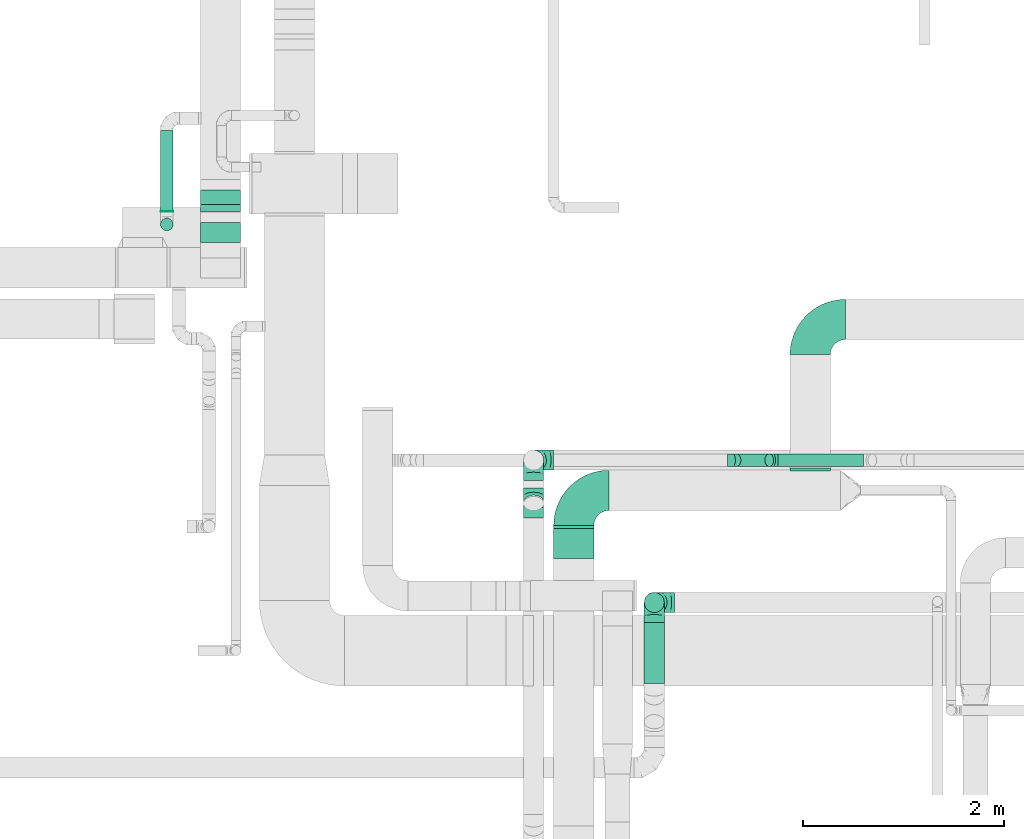
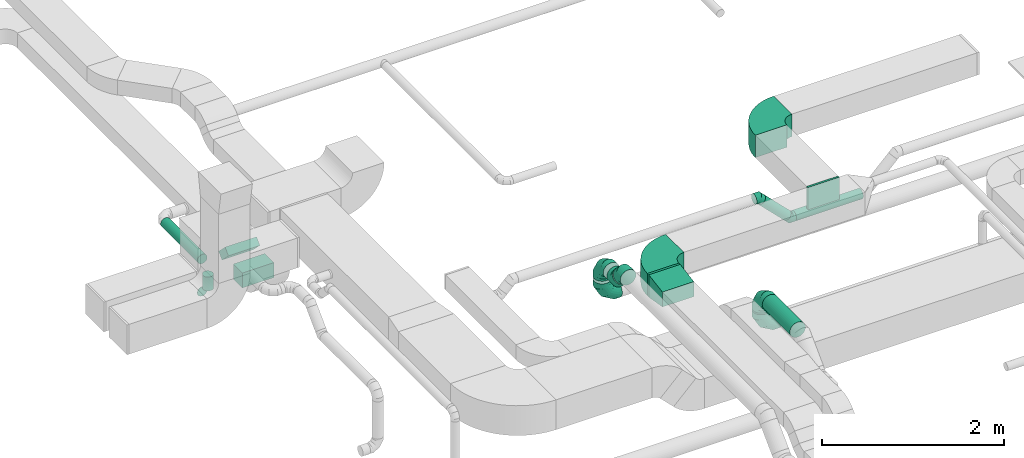
# One storey, part 32 of 60: 12 flow fittings, 10 flow segments.
"""IFC2X3 building model written with IfcOpenShell, lengths in millimetres."""

from ifc_helpers import new_model, entity, si_unit, converted_unit, derived_unit, direction, frame, frame_2d, origin, origin_2d_with_axis, place, context, subcontext, project, spatial, polyline, circle_curve, parameter, trimmed, segment, composite_curve, rectangle, circle, outline, extrude, faceted_brep, source, transform, mapped, material, type_object, type_shapes, element, save


model = new_model("IFC2X3")

# Units and contexts
model_context = context("Model", 3, precision=0.01, world=origin(), true_north=direction((6.12303176911189e-17, 1.0)))
body_context = subcontext(model_context, "Body", "Model", "MODEL_VIEW")
ifc_project = project(units=[si_unit("LENGTHUNIT", "METRE", prefix="MILLI"), si_unit("AREAUNIT", "SQUARE_METRE"), si_unit("VOLUMEUNIT", "CUBIC_METRE"), converted_unit("PLANEANGLEUNIT", "DEGREE", entity("IfcRatioMeasure", 0.0174532925199433), si_unit("PLANEANGLEUNIT", "RADIAN"), dimensions=[0, 0, 0, 0, 0, 0, 0]), si_unit("MASSUNIT", "GRAM", prefix="KILO"), derived_unit("MASSDENSITYUNIT", [(si_unit("MASSUNIT", "GRAM", prefix="KILO"), 1), (si_unit("LENGTHUNIT", "METRE"), -3)]), derived_unit("MOMENTOFINERTIAUNIT", [(si_unit("LENGTHUNIT", "METRE"), 4)]), si_unit("TIMEUNIT", "SECOND"), si_unit("FREQUENCYUNIT", "HERTZ"), si_unit("THERMODYNAMICTEMPERATUREUNIT", "DEGREE_CELSIUS"), derived_unit("THERMALTRANSMITTANCEUNIT", [(si_unit("MASSUNIT", "GRAM", prefix="KILO"), 1), (si_unit("THERMODYNAMICTEMPERATUREUNIT", "KELVIN"), -1), (si_unit("TIMEUNIT", "SECOND"), -3)]), derived_unit("VOLUMETRICFLOWRATEUNIT", [(si_unit("LENGTHUNIT", "METRE"), 3), (si_unit("TIMEUNIT", "SECOND"), -1)]), derived_unit("MASSFLOWRATEUNIT", [(si_unit("MASSUNIT", "GRAM", prefix="KILO"), 1), (si_unit("TIMEUNIT", "SECOND"), -1)]), derived_unit("ROTATIONALFREQUENCYUNIT", [(si_unit("TIMEUNIT", "SECOND"), -1)]), si_unit("ELECTRICCURRENTUNIT", "AMPERE"), si_unit("ELECTRICVOLTAGEUNIT", "VOLT"), si_unit("POWERUNIT", "WATT"), si_unit("FORCEUNIT", "NEWTON", prefix="KILO"), si_unit("ILLUMINANCEUNIT", "LUX"), si_unit("LUMINOUSFLUXUNIT", "LUMEN"), si_unit("LUMINOUSINTENSITYUNIT", "CANDELA"), derived_unit("USERDEFINED", [(si_unit("MASSUNIT", "GRAM", prefix="KILO"), -1), (si_unit("LENGTHUNIT", "METRE"), -2), (si_unit("TIMEUNIT", "SECOND"), 3), (si_unit("LUMINOUSFLUXUNIT", "LUMEN"), 1)]), derived_unit("LINEARVELOCITYUNIT", [(si_unit("LENGTHUNIT", "METRE"), 1), (si_unit("TIMEUNIT", "SECOND"), -1)]), si_unit("PRESSUREUNIT", "PASCAL"), derived_unit("USERDEFINED", [(si_unit("LENGTHUNIT", "METRE"), -2), (si_unit("MASSUNIT", "GRAM", prefix="KILO"), 1), (si_unit("TIMEUNIT", "SECOND"), -2)]), derived_unit("LINEARFORCEUNIT", [(si_unit("MASSUNIT", "GRAM", prefix="KILO"), 1), (si_unit("LENGTHUNIT", "METRE"), 1), (si_unit("TIMEUNIT", "SECOND"), -2), (si_unit("LENGTHUNIT", "METRE"), -1)]), derived_unit("PLANARFORCEUNIT", [(si_unit("MASSUNIT", "GRAM", prefix="KILO"), 1), (si_unit("LENGTHUNIT", "METRE"), 1), (si_unit("TIMEUNIT", "SECOND"), -2), (si_unit("LENGTHUNIT", "METRE"), -2)])], contexts=[model_context])

# Site, building, storey
site_placement = place(None, origin())
site = spatial("IfcSite", under=ifc_project, at=site_placement, CompositionType="ELEMENT")
building_placement = place(site_placement, origin())
building = spatial("IfcBuilding", under=site, at=building_placement, CompositionType="ELEMENT")
storey_placement = place(building_placement, frame((0.0, 0.0, 19800.0)))
storey = spatial("IfcBuildingStorey", under=building, at=storey_placement, CompositionType="ELEMENT", Elevation=19800.0)

# Flow segments
duct_segment_type_1 = type_object("IfcDuctSegmentType", PredefinedType="NOTDEFINED")
flow_segment_1_placement = place(storey_placement, frame((46370.09, 9605.34, 3350.0)))
element("IfcFlowSegment", 1, at=flow_segment_1_placement, inside=storey, type_object=duct_segment_type_1, context=body_context, shape_type="SweptSolid", body=[
    extrude(rectangle(XDim=30.000000000069, YDim=399.999999999996, at=origin_2d_with_axis()), frame((200.0, 15.0, 0.0), z_axis=(0.0, 0.0, 1.0), x_axis=(0.0, -1.0, 0.0)), (0.0, 0.0, 1.0), 300.000000000001),
])
flow_segment_2_placement = place(storey_placement, frame((42853.67, 12449.48, 2980.0)))
element("IfcFlowSegment", 2, at=flow_segment_2_placement, inside=storey, type_object=duct_segment_type_1, context=body_context, shape_type="SweptSolid", body=[
    extrude(rectangle(XDim=201.446609406728, YDim=400.000000000004, at=origin_2d_with_axis()), frame((200.0, 100.72, 0.0), z_axis=(0.0, 0.0, 1.0), x_axis=(0.0, 1.0, 0.0)), (0.0, 0.0, 1.0), 199.999999999998),
])
flow_segment_3_placement = place(storey_placement, frame((42853.67, 12756.99, 3082.51)))
element("IfcFlowSegment", 3, at=flow_segment_3_placement, inside=storey, type_object=duct_segment_type_1, context=body_context, shape_type="SweptSolid", body=[
    extrude(rectangle(XDim=104.020202535497, YDim=200.000000000001, at=origin_2d_with_axis()), frame((0.0, 107.49, 107.49), z_axis=(1.0, 0.0, 0.0), x_axis=(0.0, 0.707106781186443, 0.707106781186652)), (0.0, 0.0, 1.0), 399.999999999996),
])
duct_segment_type_2 = type_object("IfcDuctSegmentType", PredefinedType="NOTDEFINED")
flow_segment_4_placement = place(storey_placement, frame((42457.07, 12756.12, 3235.9)))
element("IfcFlowSegment", 4, at=flow_segment_4_placement, inside=storey, type_object=duct_segment_type_2, context=body_context, shape_type="SweptSolid", body=[
    extrude(circle(Radius=62.5, at=origin_2d_with_axis()), frame((64.1, 0.0, 64.1), z_axis=(0.0, 1.0, 0.0), x_axis=(-1.0, 0.0, 0.0)), (0.0, 0.0, 1.0), 808.750000000011),
])
flow_segment_5_placement = place(storey_placement, frame((42457.07, 12567.03, 2990.0)))
element("IfcFlowSegment", 5, at=flow_segment_5_placement, inside=storey, type_object=duct_segment_type_2, context=body_context, shape_type="SweptSolid", body=[
    extrude(circle(Radius=62.5, at=origin_2d_with_axis()), frame((64.1, 64.1, 0.0), z_axis=(0.0, 0.0, 1.0), x_axis=(-1.0, 0.0, 0.0)), (0.0, 0.0, 1.0), 185.000000000014),
])
flow_segment_6_placement = place(storey_placement, frame((42457.07, 12756.12, 2800.9)))
element("IfcFlowSegment", 6, at=flow_segment_6_placement, inside=storey, type_object=duct_segment_type_2, context=body_context, shape_type="SweptSolid", body=[
    extrude(circle(Radius=62.5, at=origin_2d_with_axis()), frame((64.1, 0.0, 64.1), z_axis=(0.0, 1.0, 0.0), x_axis=(1.0, 0.0, 0.0)), (0.0, 0.0, 1.0), 4.99999999999886),
])
flow_segment_7_placement = place(storey_placement, frame((47268.96, 8062.84, 3398.4)))
element("IfcFlowSegment", 7, at=flow_segment_7_placement, inside=storey, type_object=duct_segment_type_2, context=body_context, shape_type="SweptSolid", body=[
    extrude(circle(Radius=100.0, at=origin_2d_with_axis()), frame((101.6, 0.0, 101.6), z_axis=(0.0, 1.0, 0.0), x_axis=(-1.0, 0.0, 0.0)), (0.0, 0.0, 1.0), 607.161861453254),
])
flow_segment_8_placement = place(storey_placement, frame((47268.96, 8768.41, 3280.0)))
element("IfcFlowSegment", 8, at=flow_segment_8_placement, inside=storey, type_object=duct_segment_type_2, context=body_context, shape_type="SweptSolid", body=[
    extrude(circle(Radius=100.0, at=origin_2d_with_axis()), frame((101.6, 101.6, 0.0), z_axis=(0.0, 0.0, 1.0), x_axis=(-1.0, 0.0, 0.0)), (0.0, 0.0, 1.0), 20.0000000000171),
])
flow_segment_9_placement = place(storey_placement, frame((48603.52, 10221.52, 3185.9)))
element("IfcFlowSegment", 9, at=flow_segment_9_placement, inside=storey, type_object=duct_segment_type_2, context=body_context, shape_type="SweptSolid", body=[
    extrude(circle(Radius=62.5, at=origin_2d_with_axis()), frame((0.0, 64.1, 64.1), z_axis=(1.0, 0.0, 0.0), x_axis=(0.0, 1.0, 0.0)), (0.0, 0.0, 1.0), 848.406204335727),
])
flow_segment_10_placement = place(storey_placement, frame((48142.57, 10221.52, 3240.82)))
element("IfcFlowSegment", 10, at=flow_segment_10_placement, inside=storey, type_object=duct_segment_type_2, context=body_context, shape_type="SweptSolid", body=[
    extrude(circle(Radius=62.5, at=origin_2d_with_axis()), frame((45.79, 64.1, 372.57), z_axis=(0.707106781186553, 0.0, -0.707106781186542), x_axis=(0.0, 1.0, 0.0)), (0.0, 0.0, 1.0), 462.132034355938),
])

# Flow fittings
ifc_material = material()
duct_fitting_type_1 = type_object("IfcDuctFittingType", PredefinedType="NOTDEFINED", material=ifc_material)
shared_shape_1 = source(origin(), body_context, "Body", "SweptSolid", [
    extrude(rectangle(XDim=400.0, YDim=26.096000000013, at=origin_2d_with_axis()), frame((6.95, 0.0, -150.0), z_axis=(0.0, 0.0, 1.0), x_axis=(0.0, -1.0, 0.0)), (0.0, 0.0, 1.0), 300.0),
])
type_shapes(duct_fitting_type_1, [shared_shape_1])
flow_fitting_1_placement = place(storey_placement, frame((48921.97, 10185.34, 3500.0), z_axis=(0.0, 0.0, -1.0), x_axis=(0.0, 1.0, 0.0)))
element("IfcFlowFitting", 11, at=flow_fitting_1_placement, inside=storey, type_object=duct_fitting_type_1, material=ifc_material, context=body_context, shape_type="MappedRepresentation", body=[
    mapped(shared_shape_1, transform((0.0, 0.0, 0.0), scale=1.0)),
])
duct_fitting_type_2 = type_object("IfcDuctFittingType", PredefinedType="NOTDEFINED", material=ifc_material)
shared_shape_2 = source(origin(), body_context, "Body", "SweptSolid", [
    extrude(outline(polyline([(-172.62, -123.3), (131.52, -123.3), (164.4, 73.98), (-123.3, 172.62), (-172.62, -123.3)])), frame((150.0, -200.0, 0.0), z_axis=(0.0, 1.0, 0.0), x_axis=(0.986393923832128, 0.0, -0.16439898730545)), (0.0, 0.0, 1.0), 400.0),
])
type_shapes(duct_fitting_type_2, [shared_shape_2])
flow_fitting_2_placement = place(storey_placement, frame((46570.09, 9605.34, 3500.0), z_axis=(0.0, 0.0, 1.0), x_axis=(0.0, -1.0, 0.0)))
element("IfcFlowFitting", 12, at=flow_fitting_2_placement, inside=storey, type_object=duct_fitting_type_2, material=ifc_material, context=body_context, shape_type="MappedRepresentation", body=[
    mapped(shared_shape_2, transform((0.0, 0.0, 0.0), scale=1.0)),
])
duct_fitting_type_3 = type_object("IfcDuctFittingType", PredefinedType="NOTDEFINED", material=ifc_material)
shared_shape_3 = source(origin(), body_context, "Body", "Brep", [
    faceted_brep([(-200.0, 0.0, -100.0), (-200.0, -25.88, -96.59), (-200.0, -50.0, -86.6), (-200.0, -70.71, -70.71), (-200.0, -86.6, -50.0), (-200.0, -96.59, -25.88), (-200.0, -100.0, 0.0), (-200.0, -96.59, 25.88), (-200.0, -86.6, 50.0), (-200.0, -70.71, 70.71), (-200.0, -50.0, 86.6), (-200.0, -25.88, 96.59), (-200.0, 0.0, 100.0), (-200.0, 25.88, 96.59), (-200.0, 50.0, 86.6), (-200.0, 70.71, 70.71), (-200.0, 86.6, 50.0), (-200.0, 96.59, 25.88), (-200.0, 100.0, 0.0), (-200.0, 96.59, -25.88), (-200.0, 86.6, -50.0), (-200.0, 70.71, -70.71), (-200.0, 50.0, -86.6), (-200.0, 25.88, -96.59), (-153.35, 25.88, 96.59), (-159.81, 50.0, 86.6), (-146.41, 0.0, 100.0), (-165.36, 70.71, 70.71), (-172.29, 96.59, 25.88), (-173.21, 100.0, 0.0), (-169.62, 86.6, 50.0), (-169.62, 86.6, -50.0), (-165.36, 70.71, -70.71), (-172.29, 96.59, -25.88), (-153.35, 25.88, -96.59), (-146.41, 0.0, -100.0), (-159.81, 50.0, -86.6), (-139.48, -25.88, -96.59), (-133.01, -50.0, -86.6), (-127.46, -70.71, -70.71), (-123.21, -86.6, -50.0), (-120.53, -96.59, -25.88), (-119.62, -100.0, 0.0), (-120.53, -96.59, 25.88), (-123.21, -86.6, 50.0), (-127.46, -70.71, 70.71), (-133.01, -50.0, 86.6), (-139.48, -25.88, 96.59), (-72.54, 72.54, 96.59), (-90.19, 90.19, 86.6), (-53.59, 53.59, 100.0), (-105.35, 105.35, 70.71), (-116.99, 116.99, 50.0), (-124.3, 124.3, 25.88), (-126.79, 126.79, 0.0), (-124.3, 124.3, -25.88), (-116.99, 116.99, -50.0), (-105.35, 105.35, -70.71), (-72.54, 72.54, -96.59), (-53.59, 53.59, -100.0), (-90.19, 90.19, -86.6), (-34.64, 34.64, -96.59), (-16.99, 16.99, -86.6), (-1.83, 1.83, -70.71), (9.81, -9.81, -50.0), (17.12, -17.12, -25.88), (19.62, -19.62, 0.0), (17.12, -17.12, 25.88), (9.81, -9.81, 50.0), (-1.83, 1.83, 70.71), (-16.99, 16.99, 86.6), (-34.64, 34.64, 96.59), (-25.88, 153.35, 96.59), (-50.0, 159.81, 86.6), (0.0, 146.41, 100.0), (-70.71, 165.36, 70.71), (-86.6, 169.62, 50.0), (-96.59, 172.29, 25.88), (-100.0, 173.21, 0.0), (-96.59, 172.29, -25.88), (-86.6, 169.62, -50.0), (-70.71, 165.36, -70.71), (-25.88, 153.35, -96.59), (0.0, 146.41, -100.0), (-50.0, 159.81, -86.6), (25.88, 139.48, -96.59), (50.0, 133.01, -86.6), (70.71, 127.46, -70.71), (86.6, 123.21, -50.0), (96.59, 120.53, -25.88), (100.0, 119.62, 0.0), (96.59, 120.53, 25.88), (86.6, 123.21, 50.0), (70.71, 127.46, 70.71), (50.0, 133.01, 86.6), (25.88, 139.48, 96.59), (-25.88, 200.0, -96.59), (-50.0, 200.0, -86.6), (-70.71, 200.0, -70.71), (-86.6, 200.0, -50.0), (-96.59, 200.0, -25.88), (-100.0, 200.0, 0.0), (-96.59, 200.0, 25.88), (-86.6, 200.0, 50.0), (-70.71, 200.0, 70.71), (-50.0, 200.0, 86.6), (-25.88, 200.0, 96.59), (0.0, 200.0, 100.0), (25.88, 200.0, 96.59), (50.0, 200.0, 86.6), (70.71, 200.0, 70.71), (86.6, 200.0, 50.0), (96.59, 200.0, 25.88), (100.0, 200.0, 0.0), (96.59, 200.0, -25.88), (86.6, 200.0, -50.0), (70.71, 200.0, -70.71), (50.0, 200.0, -86.6), (25.88, 200.0, -96.59), (0.0, 200.0, -100.0)], [[[0, 1, 2, 3, 4, 5, 6, 7, 8, 9, 10, 11, 12, 13, 14, 15, 16, 17, 18, 19, 20, 21, 22, 23]], [[24, 25, 14, 13]], [[26, 24, 13, 12]], [[14, 25, 27, 15]], [[28, 29, 18, 17]], [[30, 28, 17, 16]], [[15, 27, 30, 16]], [[20, 31, 32, 21]], [[33, 31, 20, 19]], [[18, 29, 33, 19]], [[34, 35, 0, 23]], [[36, 34, 23, 22]], [[32, 36, 22, 21]], [[1, 0, 35, 37]], [[2, 1, 37, 38]], [[38, 39, 3, 2]], [[5, 4, 40, 41]], [[6, 5, 41, 42]], [[39, 40, 4, 3]], [[6, 42, 43, 7]], [[7, 43, 44, 8]], [[8, 44, 45, 9]], [[9, 45, 46, 10]], [[10, 46, 47, 11]], [[26, 12, 11, 47]], [[48, 49, 25, 24]], [[50, 48, 24, 26]], [[27, 25, 49, 51]], [[52, 53, 28, 30]], [[51, 52, 30, 27]], [[29, 28, 53, 54]], [[55, 56, 31, 33]], [[54, 55, 33, 29]], [[32, 31, 56, 57]], [[58, 59, 35, 34]], [[60, 58, 34, 36]], [[57, 60, 36, 32]], [[37, 35, 59, 61]], [[38, 37, 61, 62]], [[39, 38, 62, 63]], [[41, 40, 64, 65]], [[42, 41, 65, 66]], [[63, 64, 40, 39]], [[43, 42, 66, 67]], [[44, 43, 67, 68]], [[68, 69, 45, 44]], [[46, 45, 69, 70]], [[47, 46, 70, 71]], [[26, 47, 71, 50]], [[72, 73, 49, 48]], [[74, 72, 48, 50]], [[51, 49, 73, 75]], [[76, 77, 53, 52]], [[75, 76, 52, 51]], [[54, 53, 77, 78]], [[79, 80, 56, 55]], [[78, 79, 55, 54]], [[57, 56, 80, 81]], [[82, 83, 59, 58]], [[84, 82, 58, 60]], [[81, 84, 60, 57]], [[61, 59, 83, 85]], [[62, 61, 85, 86]], [[63, 62, 86, 87]], [[65, 64, 88, 89]], [[66, 65, 89, 90]], [[87, 88, 64, 63]], [[67, 66, 90, 91]], [[68, 67, 91, 92]], [[92, 93, 69, 68]], [[70, 69, 93, 94]], [[71, 70, 94, 95]], [[50, 71, 95, 74]], [[96, 97, 98, 99, 100, 101, 102, 103, 104, 105, 106, 107, 108, 109, 110, 111, 112, 113, 114, 115, 116, 117, 118, 119]], [[72, 74, 107, 106]], [[73, 72, 106, 105]], [[75, 73, 105, 104]], [[102, 101, 78, 77]], [[103, 102, 77, 76]], [[75, 104, 103, 76]], [[78, 101, 100, 79]], [[79, 100, 99, 80]], [[80, 99, 98, 81]], [[84, 97, 96, 82]], [[82, 96, 119, 83]], [[84, 81, 98, 97]], [[118, 117, 86, 85]], [[119, 118, 85, 83]], [[116, 87, 86, 117]], [[88, 115, 114, 89]], [[89, 114, 113, 90]], [[115, 88, 87, 116]], [[91, 90, 113, 112]], [[92, 91, 112, 111]], [[111, 110, 93, 92]], [[95, 94, 109, 108]], [[74, 95, 108, 107]], [[110, 109, 94, 93]]]),
])
type_shapes(duct_fitting_type_3, [shared_shape_3])
for number, where, z_axis, x_axis in (
    (13, (47370.56, 8870.01, 3500.0), (1.0, 0.0, 0.0), (0.0, 0.0, 1.0)),
    (14, (47370.56, 8870.01, 3080.0), (0.0, -1.0, 0.0), (0.0, 0.0, -1.0)),
    (15, (46170.4, 10285.62, 3490.0), (1.0, 0.0, 0.0), (0.0, 0.0, 1.0)),
    (16, (46170.4, 10285.62, 3055.0), (0.0, -1.0, 0.0), (0.0, 0.0, -1.0)),
):
    element("IfcFlowFitting", number, at=place(storey_placement, frame(where, z_axis=z_axis, x_axis=x_axis)), inside=storey, type_object=duct_fitting_type_3, material=ifc_material, context=body_context, shape_type="MappedRepresentation", body=[
        mapped(shared_shape_3, transform((0.0, 0.0, 0.0), scale=1.0)),
    ])
duct_fitting_type_4 = type_object("IfcDuctFittingType", PredefinedType="NOTDEFINED", material=ifc_material)
shared_shape_4 = source(origin(), body_context, "Body", "Brep", [
    faceted_brep([(-51.78, 0.0, -62.5), (-51.78, -16.18, -60.37), (-51.78, -31.25, -54.13), (-51.78, -44.19, -44.19), (-51.78, -54.13, -31.25), (-51.78, -60.37, -16.18), (-51.78, -62.5, 0.0), (-51.78, -60.37, 16.18), (-51.78, -54.13, 31.25), (-51.78, -44.19, 44.19), (-51.78, -31.25, 54.13), (-51.78, -16.18, 60.37), (-51.78, 0.0, 62.5), (-51.78, 16.18, 60.37), (-51.78, 31.25, 54.13), (-51.78, 44.19, 44.19), (-51.78, 54.13, 31.25), (-51.78, 60.37, 16.18), (-51.78, 62.5, 0.0), (-51.78, 60.37, -16.18), (-51.78, 54.13, -31.25), (-51.78, 44.19, -44.19), (-51.78, 31.25, -54.13), (-51.78, 16.18, -60.37), (-6.7, 16.18, 60.37), (-12.94, 31.25, 54.13), (0.0, 0.0, 62.5), (-18.31, 44.19, 44.19), (-22.42, 54.13, 31.25), (-25.01, 60.37, 16.18), (-25.89, 62.5, 0.0), (-25.01, 60.37, -16.18), (-22.42, 54.13, -31.25), (-18.31, 44.19, -44.19), (-6.7, 16.18, -60.37), (0.0, 0.0, -62.5), (-12.94, 31.25, -54.13), (6.7, -16.18, -60.37), (12.94, -31.25, -54.13), (18.31, -44.19, -44.19), (22.42, -54.13, -31.25), (25.01, -60.37, -16.18), (25.89, -62.5, 0.0), (25.01, -60.37, 16.18), (22.42, -54.13, 31.25), (18.31, -44.19, 44.19), (12.94, -31.25, 54.13), (6.7, -16.18, 60.37), (25.17, 48.05, 60.37), (14.51, 58.71, 54.13), (36.61, 36.61, 62.5), (5.36, 67.86, 44.19), (-1.66, 74.88, 31.25), (-6.08, 79.3, 16.18), (-7.58, 80.81, 0.0), (-6.08, 79.3, -16.18), (-1.66, 74.88, -31.25), (5.36, 67.86, -44.19), (14.51, 58.71, -54.13), (25.17, 48.05, -60.37), (36.61, 36.61, -62.5), (48.05, 25.17, -60.37), (58.71, 14.51, -54.13), (67.86, 5.36, -44.19), (74.88, -1.66, -31.25), (79.3, -6.08, -16.18), (80.81, -7.58, 0.0), (79.3, -6.08, 16.18), (74.88, -1.66, 31.25), (67.86, 5.36, 44.19), (58.71, 14.51, 54.13), (48.05, 25.17, 60.37)], [[[0, 1, 2, 3, 4, 5, 6, 7, 8, 9, 10, 11, 12, 13, 14, 15, 16, 17, 18, 19, 20, 21, 22, 23]], [[24, 25, 14, 13]], [[26, 24, 13, 12]], [[27, 15, 14, 25]], [[28, 29, 17, 16]], [[28, 16, 15, 27]], [[30, 18, 17, 29]], [[31, 32, 20, 19]], [[30, 31, 19, 18]], [[21, 20, 32, 33]], [[34, 35, 0, 23]], [[36, 34, 23, 22]], [[33, 36, 22, 21]], [[1, 0, 35, 37]], [[2, 1, 37, 38]], [[38, 39, 3, 2]], [[5, 4, 40, 41]], [[6, 5, 41, 42]], [[39, 40, 4, 3]], [[6, 42, 43, 7]], [[7, 43, 44, 8]], [[8, 44, 45, 9]], [[9, 45, 46, 10]], [[10, 46, 47, 11]], [[26, 12, 11, 47]], [[48, 49, 25, 24]], [[50, 48, 24, 26]], [[27, 25, 49, 51]], [[29, 28, 52, 53]], [[30, 29, 53, 54]], [[51, 52, 28, 27]], [[30, 54, 55, 31]], [[31, 55, 56, 32]], [[57, 33, 32, 56]], [[36, 58, 59, 34]], [[34, 59, 60, 35]], [[58, 36, 33, 57]], [[35, 60, 61, 37]], [[37, 61, 62, 38]], [[63, 39, 38, 62]], [[40, 64, 65, 41]], [[41, 65, 66, 42]], [[64, 40, 39, 63]], [[43, 42, 66, 67]], [[44, 43, 67, 68]], [[68, 69, 45, 44]], [[47, 46, 70, 71]], [[26, 47, 71, 50]], [[69, 70, 46, 45]], [[59, 58, 57, 56, 55, 54, 53, 52, 51, 49, 48, 50, 71, 70, 69, 68, 67, 66, 65, 64, 63, 62, 61, 60]]]),
])
type_shapes(duct_fitting_type_4, [shared_shape_4])
for number, where, z_axis, x_axis in (
    (17, (48551.74, 10285.62, 3250.0), (0.0, 1.0, 0.0), (-1.0, 0.0, 0.0)),
    (18, (48151.74, 10285.62, 3650.0), (0.0, -1.0, 0.0), (-0.707106781186505, 0.0, 0.70710678118659)),
):
    element("IfcFlowFitting", number, at=place(storey_placement, frame(where, z_axis=z_axis, x_axis=x_axis)), inside=storey, type_object=duct_fitting_type_4, material=ifc_material, context=body_context, shape_type="MappedRepresentation", body=[
        mapped(shared_shape_4, transform((0.0, 0.0, 0.0), scale=1.0)),
    ])
duct_fitting_type_5 = type_object("IfcDuctFittingType", PredefinedType="NOTDEFINED", material=ifc_material)
shared_shape_5 = source(origin(), body_context, "Body", "Brep", [
    faceted_brep([(-82.84, 0.0, -100.0), (-82.84, -25.88, -96.59), (-82.84, -50.0, -86.6), (-82.84, -70.71, -70.71), (-82.84, -86.6, -50.0), (-82.84, -96.59, -25.88), (-82.84, -100.0, 0.0), (-82.84, -96.59, 25.88), (-82.84, -86.6, 50.0), (-82.84, -70.71, 70.71), (-82.84, -50.0, 86.6), (-82.84, -25.88, 96.59), (-82.84, 0.0, 100.0), (-82.84, 25.88, 96.59), (-82.84, 50.0, 86.6), (-82.84, 70.71, 70.71), (-82.84, 86.6, 50.0), (-82.84, 96.59, 25.88), (-82.84, 100.0, 0.0), (-82.84, 96.59, -25.88), (-82.84, 86.6, -50.0), (-82.84, 70.71, -70.71), (-82.84, 50.0, -86.6), (-82.84, 25.88, -96.59), (-10.72, 25.88, 96.59), (-20.71, 50.0, 86.6), (0.0, 0.0, 100.0), (-29.29, 70.71, 70.71), (-35.87, 86.6, 50.0), (-40.01, 96.59, 25.88), (-41.42, 100.0, 0.0), (-40.01, 96.59, -25.88), (-35.87, 86.6, -50.0), (-29.29, 70.71, -70.71), (-10.72, 25.88, -96.59), (0.0, 0.0, -100.0), (-20.71, 50.0, -86.6), (10.72, -25.88, -96.59), (20.71, -50.0, -86.6), (29.29, -70.71, -70.71), (35.87, -86.6, -50.0), (40.01, -96.59, -25.88), (41.42, -100.0, 0.0), (40.01, -96.59, 25.88), (35.87, -86.6, 50.0), (29.29, -70.71, 70.71), (20.71, -50.0, 86.6), (10.72, -25.88, 96.59), (58.58, 58.58, 100.0), (40.28, 76.88, 96.59), (23.22, 93.93, 86.6), (8.58, 108.58, 70.71), (-2.66, 119.82, 50.0), (-9.72, 126.88, 25.88), (-12.13, 129.29, 0.0), (-9.72, 126.88, -25.88), (-2.66, 119.82, -50.0), (8.58, 108.58, -70.71), (23.22, 93.93, -86.6), (40.28, 76.88, -96.59), (58.58, 58.58, -100.0), (76.88, 40.28, -96.59), (93.93, 23.22, -86.6), (108.58, 8.58, -70.71), (119.82, -2.66, -50.0), (126.88, -9.72, -25.88), (129.29, -12.13, 0.0), (126.88, -9.72, 25.88), (119.82, -2.66, 50.0), (108.58, 8.58, 70.71), (93.93, 23.22, 86.6), (76.88, 40.28, 96.59)], [[[0, 1, 2, 3, 4, 5, 6, 7, 8, 9, 10, 11, 12, 13, 14, 15, 16, 17, 18, 19, 20, 21, 22, 23]], [[24, 25, 14, 13]], [[26, 24, 13, 12]], [[14, 25, 27, 15]], [[28, 29, 17, 16]], [[28, 16, 15, 27]], [[30, 18, 17, 29]], [[31, 32, 20, 19]], [[30, 31, 19, 18]], [[32, 33, 21, 20]], [[34, 35, 0, 23]], [[36, 34, 23, 22]], [[33, 36, 22, 21]], [[1, 0, 35, 37]], [[2, 1, 37, 38]], [[38, 39, 3, 2]], [[5, 4, 40, 41]], [[6, 5, 41, 42]], [[39, 40, 4, 3]], [[6, 42, 43, 7]], [[7, 43, 44, 8]], [[8, 44, 45, 9]], [[9, 45, 46, 10]], [[10, 46, 47, 11]], [[26, 12, 11, 47]], [[24, 26, 48, 49]], [[25, 24, 49, 50]], [[27, 25, 50, 51]], [[29, 28, 52, 53]], [[30, 29, 53, 54]], [[51, 52, 28, 27]], [[30, 54, 55, 31]], [[31, 55, 56, 32]], [[57, 33, 32, 56]], [[36, 58, 59, 34]], [[34, 59, 60, 35]], [[58, 36, 33, 57]], [[35, 60, 61, 37]], [[37, 61, 62, 38]], [[63, 39, 38, 62]], [[40, 64, 65, 41]], [[41, 65, 66, 42]], [[64, 40, 39, 63]], [[43, 42, 66, 67]], [[44, 43, 67, 68]], [[68, 69, 45, 44]], [[47, 46, 70, 71]], [[26, 47, 71, 48]], [[69, 70, 46, 45]], [[59, 58, 57, 56, 55, 54, 53, 52, 51, 50, 49, 48, 71, 70, 69, 68, 67, 66, 65, 64, 63, 62, 61, 60]]]),
])
type_shapes(duct_fitting_type_5, [shared_shape_5])
for number, where, z_axis, x_axis in (
    (19, (46170.4, 9925.62, 3490.0), (-1.0, 0.0, 0.0), (0.0, -1.0, 0.0)),
    (20, (46170.4, 9795.62, 3620.0), (1.0, 0.0, 0.0), (0.0, -0.70710678118619, 0.707106781186905)),
):
    element("IfcFlowFitting", number, at=place(storey_placement, frame(where, z_axis=z_axis, x_axis=x_axis)), inside=storey, type_object=duct_fitting_type_5, material=ifc_material, context=body_context, shape_type="MappedRepresentation", body=[
        mapped(shared_shape_5, transform((0.0, 0.0, 0.0), scale=1.0)),
    ])
duct_fitting_type_6 = type_object("IfcDuctFittingType", PredefinedType="NOTDEFINED", material=ifc_material)
shared_shape_6 = source(origin(), body_context, "Body", "SweptSolid", [
    extrude(outline(composite_curve([segment(polyline([(-375.0, -175.0), (25.0, -175.0)]), True, "CONTINUOUS"), segment(trimmed(circle_curve(frame_2d((175.0, -175.0), x_axis=(0.0, 1.0)), 150.0), [parameter(0.0)], [parameter(90.0000000000001)], True, "PARAMETER"), False, "CONTINUOUS"), segment(polyline([(175.0, -25.0), (175.0, 375.0)]), True, "CONTINUOUS"), segment(trimmed(circle_curve(frame_2d((175.0, -175.0), x_axis=(0.0, 1.0)), 550.0), [parameter(0.0)], [parameter(90.0)], True, "PARAMETER"), True, "CONTINUOUS")], self_intersect=False)), frame((-175.0, 175.0, -150.0), z_axis=(0.0, 0.0, 1.0), x_axis=(-1.0, 0.0, 0.0)), (0.0, 0.0, 1.0), 300.0),
])
type_shapes(duct_fitting_type_6, [shared_shape_6])
for number, where, z_axis, x_axis in (
    (21, (46570.09, 9985.34, 3500.0), (0.0, 0.0, 1.0), (-1.0, 0.0, 0.0)),
    (22, (48921.97, 11685.34, 3500.0), (0.0, 0.0, 1.0), (-1.0, 0.0, 0.0)),
):
    element("IfcFlowFitting", number, at=place(storey_placement, frame(where, z_axis=z_axis, x_axis=x_axis)), inside=storey, type_object=duct_fitting_type_6, material=ifc_material, context=body_context, shape_type="MappedRepresentation", body=[
        mapped(shared_shape_6, transform((0.0, 0.0, 0.0), scale=1.0)),
    ])

save(model, "model.ifc")
